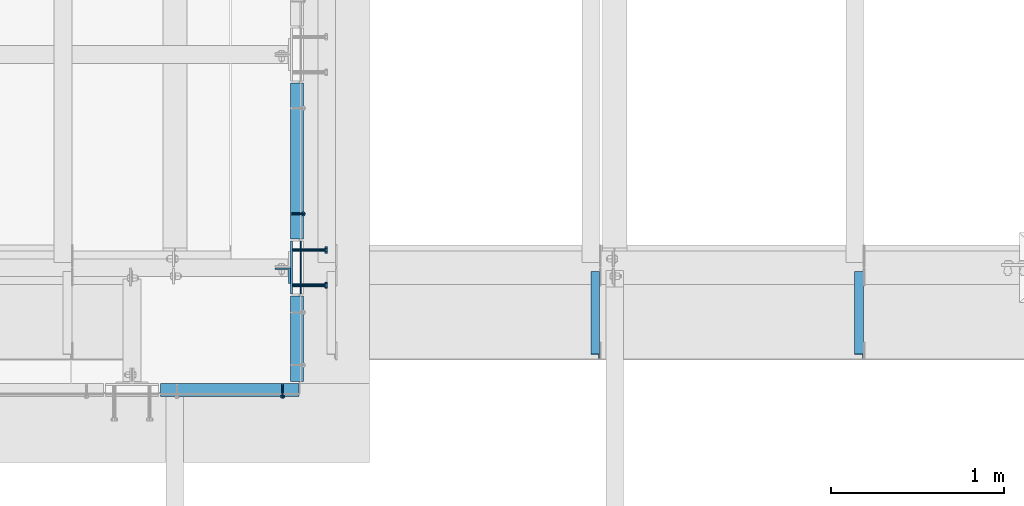
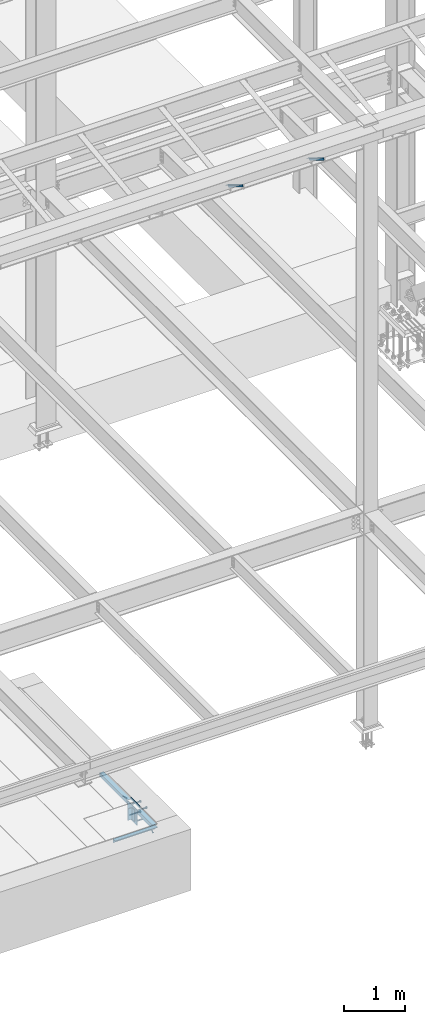
# One storey, part 2054 of 3843: 10 beams, 4 members, 7 elements without a shape of their own.
"""IFC2X3 building model written with IfcOpenShell, lengths in millimetres."""

from ifc_helpers import new_model, si_unit, frame, origin_with_axes, place, context, subcontext, project, spatial, faceted_brep, material, type_object, element, aggregate, save


model = new_model("IFC2X3")

# Units and contexts
model_context = context("Model", 3, precision=1e-05, world=origin_with_axes())
body_context = subcontext(model_context, "Body", "Model", "MODEL_VIEW")
ifc_project = project(units=[si_unit("LENGTHUNIT", "METRE", prefix="MILLI"), si_unit("AREAUNIT", "SQUARE_METRE"), si_unit("VOLUMEUNIT", "CUBIC_METRE"), si_unit("MASSUNIT", "GRAM", prefix="KILO"), si_unit("TIMEUNIT", "SECOND"), si_unit("PLANEANGLEUNIT", "RADIAN"), si_unit("SOLIDANGLEUNIT", "STERADIAN"), si_unit("THERMODYNAMICTEMPERATUREUNIT", "DEGREE_CELSIUS"), si_unit("LUMINOUSINTENSITYUNIT", "LUMEN")], contexts=[model_context])

# Site, building, storey
site_placement = place(None, origin_with_axes())
site = spatial("IfcSite", under=ifc_project, at=site_placement, CompositionType="ELEMENT")
building_placement = place(site_placement, origin_with_axes())
building = spatial("IfcBuilding", under=site, at=building_placement, Name="Undefined", CompositionType="ELEMENT")
storey_placement = place(building_placement, origin_with_axes())
storey = spatial("IfcBuildingStorey", under=building, at=storey_placement, Name="Undefined", CompositionType="ELEMENT", Elevation=0.0)

# Assembly, beam
assembly_1_placement = place(storey_placement, origin_with_axes())
assembly_1 = element("IfcElementAssembly", 1, at=assembly_1_placement, inside=storey, Name="EMBED PLATE", AssemblyPlace="NOTDEFINED", PredefinedType="RIGID_FRAME")
ifc_material_1 = material(Name="STEEL/A36")
beam_type_1 = type_object("IfcBeamType", PredefinedType="NOTDEFINED")
beam_1_placement = place(assembly_1_placement, frame((65903.475, 15151.1, 30454.6), z_axis=(0.0, 0.0, 1.0), x_axis=(0.0, -1.0, 0.0)))
beam_1 = element("IfcBeam", 2, at=beam_1_placement, type_object=beam_type_1, material=ifc_material_1, Name="PLATE", context=body_context, shape_type="Brep", body=[
    faceted_brep([(0.0, 3.17499999999927, -25.4000000000015), (0.0, 3.17499999999927, 25.4000000000015), (304.800000000003, 3.17500000000291, 25.4000000000015), (304.800000000003, 3.17500000000291, -25.4000000000015), (0.0, -3.17499999999927, 25.4000000000015), (304.800000000003, -3.17500000000291, 25.4000000000015), (0.0, -3.17499999999927, -25.4000000000015), (304.800000000003, -3.17500000000291, -25.4000000000015)], [[[0, 1, 2, 3]], [[1, 4, 5, 2]], [[4, 6, 7, 5]], [[6, 0, 3, 7]], [[5, 7, 3, 2]], [[6, 4, 1, 0]]]),
])

# Assembly, member
assembly_2_placement = place(storey_placement, origin_with_axes())
assembly_2 = element("IfcElementAssembly", 3, at=assembly_2_placement, inside=storey, Name="ANGLE", AssemblyPlace="NOTDEFINED", PredefinedType="RIGID_FRAME")
ifc_material_2 = material(Name="STEEL/A108")
member_type_1 = type_object("IfcMemberType", PredefinedType="NOTDEFINED")
member_1_placement = place(assembly_2_placement, frame((65849.5000002649, 15309.0561677558, 30422.8500045777), z_axis=(0.0, 1.0, 0.0), x_axis=(0.707106781186548, 0.0, -0.707106781186548)))
member_1 = element("IfcMember", 4, at=member_1_placement, type_object=member_type_1, material=ifc_material_2, Name="HEADED STUD ANCHOR", context=body_context, shape_type="Brep", body=[
    faceted_brep([(7.27595761418343e-12, -3.18000006675175, 5.5), (0.0, -5.49999999998363, 3.1800000667572), (94.4879985803855, -5.50000000011278, 3.1800000667572), (94.4879985803782, -3.18000006687362, 5.5), (0.0, -6.3499999046162, 0.0), (94.4879985803855, -6.34999990474535, 0.0), (0.0, -5.49999999998363, -3.1800000667572), (94.4879985803855, -5.50000000011278, -3.1800000667572), (7.27595761418343e-12, -3.18000006675175, -5.5), (94.4879985803782, -3.18000006687362, -5.5), (7.27595761418343e-12, -1.81898940354586e-12, -6.34999990463257), (94.4879985803782, -1.20053300634027e-10, -6.34999990463257), (0.0, 3.18000006675175, -5.5), (94.4879985803709, 3.18000006663351, -5.5), (7.27595761418343e-12, 5.49999999998363, -3.1800000667572), (94.4879985803709, 5.49999999987267, -3.1800000667572), (7.27595761418343e-12, 6.3499999046162, 0.0), (94.4879985803673, 6.34999990450706, 0.0), (7.27595761418343e-12, 5.49999999998363, 3.1800000667572), (94.4879985803709, 5.49999999987267, 3.1800000667572), (0.0, 3.18000006675175, 5.5), (94.4879985803709, 3.18000006663351, 5.5), (7.27595761418343e-12, -1.81898940354586e-12, 6.34999990463257), (94.4879985803782, -1.20053300634027e-10, 6.34999990463257), (96.5199985498621, -10.9899997712273, 6.34999990463257), (96.5199985498548, -6.34000015270249, 10.9899997711182), (96.5199985498621, -12.6999998093743, 0.0), (96.5199985498621, -10.9899997712273, -6.34999990463257), (96.5199985498548, -6.34000015270249, -10.9899997711182), (96.5199985498475, -1.21872290037572e-10, -12.6899995803833), (96.5199985498402, 6.34000015245874, -10.9899997711182), (96.519998549833, 10.9899997709817, -6.34999990463257), (96.519998549833, 12.6999998091305, 0.0), (96.519998549833, 10.9899997709817, 6.34999990463257), (96.5199985498402, 6.34000015245874, 10.9899997711182), (96.5199985498475, -1.21872290037572e-10, 12.6899995803833), (101.599998473539, -10.9899997712328, 6.34999990463257), (101.599998473532, -6.34000015270976, 10.9899997711182), (101.599998473539, -12.6999998093797, 0.0), (101.599998473539, -10.9899997712328, -6.34999990463257), (101.599998473532, -6.34000015270976, -10.9899997711182), (101.599998473524, -1.29148247651756e-10, -12.6899995803833), (101.599998473517, 6.34000015245329, -10.9899997711182), (101.59999847351, 10.9899997709763, -6.34999990463257), (101.599998473503, 12.6999998091196, 0.0), (101.59999847351, 10.9899997709763, 6.34999990463257), (101.599998473517, 6.34000015245329, 10.9899997711182), (101.599998473524, -1.29148247651756e-10, 12.6899995803833)], [[[0, 1, 2, 3]], [[1, 4, 5, 2]], [[4, 6, 7, 5]], [[6, 8, 9, 7]], [[8, 10, 11, 9]], [[10, 12, 13, 11]], [[12, 14, 15, 13]], [[14, 16, 17, 15]], [[16, 18, 19, 17]], [[18, 20, 21, 19]], [[20, 22, 23, 21]], [[22, 0, 3, 23]], [[22, 20, 18, 16, 14, 12, 10, 8, 6, 4, 1, 0]], [[3, 2, 24, 25]], [[2, 5, 26, 24]], [[5, 7, 27, 26]], [[7, 9, 28, 27]], [[9, 11, 29, 28]], [[11, 13, 30, 29]], [[13, 15, 31, 30]], [[15, 17, 32, 31]], [[17, 19, 33, 32]], [[19, 21, 34, 33]], [[21, 23, 35, 34]], [[23, 3, 25, 35]], [[25, 24, 36, 37]], [[24, 26, 38, 36]], [[26, 27, 39, 38]], [[27, 28, 40, 39]], [[28, 29, 41, 40]], [[29, 30, 42, 41]], [[30, 31, 43, 42]], [[31, 32, 44, 43]], [[32, 33, 45, 44]], [[33, 34, 46, 45]], [[34, 35, 47, 46]], [[35, 25, 37, 47]], [[38, 39, 40, 41, 42, 43, 44, 45, 46, 47, 37, 36]]]),
])

assembly_3_placement = place(storey_placement, origin_with_axes())
assembly_3 = element("IfcElementAssembly", 5, at=assembly_3_placement, inside=storey, Name="ANGLE", AssemblyPlace="NOTDEFINED", PredefinedType="RIGID_FRAME")
member_2_placement = place(assembly_3_placement, frame((65798.7000335676, 14322.4250721639, 30422.8500024177), z_axis=(1.0, 0.0, 0.0), x_axis=(0.0, -0.707106781186548, -0.707106781186548)))
member_2 = element("IfcMember", 6, at=member_2_placement, type_object=member_type_1, material=ifc_material_2, Name="HEADED STUD ANCHOR", context=body_context, shape_type="Brep", body=[
    faceted_brep([(7.27595761418343e-12, -3.18000006675175, 5.5), (0.0, -5.49999999998363, 3.1800000667572), (94.4879985803855, -5.50000000011278, 3.1800000667572), (94.4879985803782, -3.18000006687362, 5.5), (0.0, -6.3499999046162, 0.0), (94.4879985803855, -6.34999990474535, 0.0), (0.0, -5.49999999998363, -3.1800000667572), (94.4879985803855, -5.50000000011278, -3.1800000667572), (7.27595761418343e-12, -3.18000006675175, -5.5), (94.4879985803782, -3.18000006687362, -5.5), (7.27595761418343e-12, -1.81898940354586e-12, -6.34999990463257), (94.4879985803782, -1.20053300634027e-10, -6.34999990463257), (0.0, 3.18000006675175, -5.5), (94.4879985803709, 3.18000006663351, -5.5), (7.27595761418343e-12, 5.49999999998363, -3.1800000667572), (94.4879985803709, 5.49999999987267, -3.1800000667572), (7.27595761418343e-12, 6.3499999046162, 0.0), (94.4879985803673, 6.34999990450706, 0.0), (7.27595761418343e-12, 5.49999999998363, 3.1800000667572), (94.4879985803709, 5.49999999987267, 3.1800000667572), (0.0, 3.18000006675175, 5.5), (94.4879985803709, 3.18000006663351, 5.5), (7.27595761418343e-12, -1.81898940354586e-12, 6.34999990463257), (94.4879985803782, -1.20053300634027e-10, 6.34999990463257), (96.5199985498621, -10.9899997712273, 6.34999990463257), (96.5199985498548, -6.34000015270249, 10.9899997711182), (96.5199985498621, -12.6999998093743, 0.0), (96.5199985498621, -10.9899997712273, -6.34999990463257), (96.5199985498548, -6.34000015270249, -10.9899997711182), (96.5199985498475, -1.21872290037572e-10, -12.6899995803833), (96.5199985498402, 6.34000015245874, -10.9899997711182), (96.519998549833, 10.9899997709817, -6.34999990463257), (96.519998549833, 12.6999998091305, 0.0), (96.519998549833, 10.9899997709817, 6.34999990463257), (96.5199985498402, 6.34000015245874, 10.9899997711182), (96.5199985498475, -1.21872290037572e-10, 12.6899995803833), (101.599998473539, -10.9899997712328, 6.34999990463257), (101.599998473532, -6.34000015270976, 10.9899997711182), (101.599998473539, -12.6999998093797, 0.0), (101.599998473539, -10.9899997712328, -6.34999990463257), (101.599998473532, -6.34000015270976, -10.9899997711182), (101.599998473524, -1.29148247651756e-10, -12.6899995803833), (101.599998473517, 6.34000015245329, -10.9899997711182), (101.59999847351, 10.9899997709763, -6.34999990463257), (101.599998473503, 12.6999998091196, 0.0), (101.59999847351, 10.9899997709763, 6.34999990463257), (101.599998473517, 6.34000015245329, 10.9899997711182), (101.599998473524, -1.29148247651756e-10, 12.6899995803833)], [[[0, 1, 2, 3]], [[1, 4, 5, 2]], [[4, 6, 7, 5]], [[6, 8, 9, 7]], [[8, 10, 11, 9]], [[10, 12, 13, 11]], [[12, 14, 15, 13]], [[14, 16, 17, 15]], [[16, 18, 19, 17]], [[18, 20, 21, 19]], [[20, 22, 23, 21]], [[22, 0, 3, 23]], [[22, 20, 18, 16, 14, 12, 10, 8, 6, 4, 1, 0]], [[3, 2, 24, 25]], [[2, 5, 26, 24]], [[5, 7, 27, 26]], [[7, 9, 28, 27]], [[9, 11, 29, 28]], [[11, 13, 30, 29]], [[13, 15, 31, 30]], [[15, 17, 32, 31]], [[17, 19, 33, 32]], [[19, 21, 34, 33]], [[21, 23, 35, 34]], [[23, 3, 25, 35]], [[25, 24, 36, 37]], [[24, 26, 38, 36]], [[26, 27, 39, 38]], [[27, 28, 40, 39]], [[28, 29, 41, 40]], [[29, 30, 42, 41]], [[30, 31, 43, 42]], [[31, 32, 44, 43]], [[32, 33, 45, 44]], [[33, 34, 46, 45]], [[34, 35, 47, 46]], [[35, 25, 37, 47]], [[38, 39, 40, 41, 42, 43, 44, 45, 46, 47, 37, 36]]]),
])

# Beam
beam_type_2 = type_object("IfcBeamType", PredefinedType="NOTDEFINED")
beam_2_placement = place(assembly_1_placement, frame((65849.5, 14998.7, 30422.85), z_axis=(0.0, -1.0, 0.0), x_axis=(0.0, 0.0, -1.0)))
beam_2 = element("IfcBeam", 7, at=beam_2_placement, type_object=beam_type_2, material=ifc_material_1, Name="EMBED PLATE", context=body_context, shape_type="Brep", body=[
    faceted_brep([(-1.0550138540566e-10, 6.34999999999854, -152.400000000664), (1.0550138540566e-10, 6.34999999999854, 152.400000000656), (304.799999999999, 6.34999999999854, 152.400000000001), (304.799999999999, 6.34999999999854, -152.400000000001), (1.0550138540566e-10, -6.34999999999854, 152.400000000656), (304.799999999999, -6.34999999999854, 152.400000000001), (-1.0550138540566e-10, -6.34999999999854, -152.400000000664), (304.799999999999, -6.34999999999854, -152.400000000001)], [[[0, 1, 2, 3]], [[1, 4, 5, 2]], [[4, 6, 7, 5]], [[6, 0, 3, 7]], [[5, 7, 3, 2]], [[6, 4, 1, 0]]]),
])

# Assembly, member
assembly_4_placement = place(storey_placement, origin_with_axes())
assembly_4 = element("IfcElementAssembly", 8, at=assembly_4_placement, inside=storey, Name="ANGLE", AssemblyPlace="NOTDEFINED", PredefinedType="RIGID_FRAME")
ifc_material_3 = material(Name="STEEL/A572-50")
member_type_2 = type_object("IfcMemberType", Name="L2X2X1/4", PredefinedType="NOTDEFINED")
member_3_placement = place(assembly_4_placement, frame((69127.6875, 14962.4615149769, 42136.6100587905), z_axis=(-1.0, 0.0, 0.0), x_axis=(0.0, -0.851012521472712, 0.5251453972917)))
member_3 = element("IfcMember", 9, at=member_3_placement, type_object=member_type_2, material=ifc_material_3, Name="ANGLE", ObjectType="L2X2X1/4", context=body_context, shape_type="Brep", body=[
    faceted_brep([(0.0, 25.4000000000015, -25.4000000000015), (0.0, 25.4000000000015, 25.4000000000015), (558.799999999297, 25.3999999986918, 25.3999999999942), (558.799999999297, 25.3999999986918, -25.3999999999942), (0.0, 19.0500000000029, 25.4000000000015), (558.799999999297, 19.049999998686, 25.3999999999942), (0.0, 19.0500000000029, -19.0499999999993), (558.799999999297, 19.049999998686, -19.0500000000029), (0.0, -25.4000000000015, -19.0499999999993), (558.799999999281, -25.4000000013912, -19.0500000000029), (0.0, -25.4000000000015, -25.4000000000015), (558.799999999281, -25.4000000013912, -25.3999999999942)], [[[0, 1, 2, 3]], [[1, 4, 5, 2]], [[4, 6, 7, 5]], [[6, 8, 9, 7]], [[8, 10, 11, 9]], [[10, 0, 3, 11]], [[5, 7, 9, 11, 3, 2]], [[10, 8, 6, 4, 1, 0]]]),
])
aggregate(assembly_4, [member_3])

assembly_5_placement = place(storey_placement, origin_with_axes())
assembly_5 = element("IfcElementAssembly", 10, at=assembly_5_placement, inside=storey, Name="ANGLE", AssemblyPlace="NOTDEFINED", PredefinedType="RIGID_FRAME")
member_4_placement = place(assembly_5_placement, frame((67603.6875, 14962.4615149769, 42136.6100587905), z_axis=(-1.0, 0.0, 0.0), x_axis=(0.0, -0.851012521472712, 0.5251453972917)))
member_4 = element("IfcMember", 11, at=member_4_placement, type_object=member_type_2, material=ifc_material_3, Name="ANGLE", ObjectType="L2X2X1/4", context=body_context, shape_type="Brep", body=[
    faceted_brep([(0.0, 25.4000000000015, -25.4000000000015), (0.0, 25.4000000000015, 25.4000000000015), (558.799999999297, 25.3999999986918, 25.3999999999942), (558.799999999297, 25.3999999986918, -25.3999999999942), (0.0, 19.0500000000029, 25.4000000000015), (558.799999999297, 19.049999998686, 25.3999999999942), (0.0, 19.0500000000029, -19.0499999999993), (558.799999999297, 19.049999998686, -19.0500000000029), (0.0, -25.4000000000015, -19.0499999999993), (558.799999999281, -25.4000000013912, -19.0500000000029), (0.0, -25.4000000000015, -25.4000000000015), (558.799999999281, -25.4000000013912, -25.3999999999942)], [[[0, 1, 2, 3]], [[1, 4, 5, 2]], [[4, 6, 7, 5]], [[6, 8, 9, 7]], [[8, 10, 11, 9]], [[10, 0, 3, 11]], [[5, 7, 9, 11, 3, 2]], [[10, 8, 6, 4, 1, 0]]]),
])
aggregate(assembly_5, [member_4])

# Beam
beam_type_3 = type_object("IfcBeamType", Name="L3X3X1/4", PredefinedType="NOTDEFINED")
beam_3_placement = place(assembly_2_placement, frame((65881.2499980018, 16063.9121401411, 30391.1000045777), z_axis=(0.0, 0.0, -1.0), x_axis=(0.0, -1.0, 0.0)))
beam_3 = element("IfcBeam", 12, at=beam_3_placement, type_object=beam_type_3, material=ifc_material_1, Name="ANGLE", ObjectType="L3X3X1/4", context=body_context, shape_type="Brep", body=[
    faceted_brep([(0.0, 38.0999999999985, -38.0999999999985), (0.0, 38.0999999999985, 38.0999999999985), (900.112000000037, 38.1000000023996, 38.0999999999985), (900.112000000037, 38.1000000023996, -38.0999999999985), (0.0, 31.75, 38.0999999999985), (900.11200000003, 31.7500000023938, 38.0999999999985), (0.0, 31.75, -31.75), (900.11200000003, 31.7500000023938, -31.75), (0.0, -38.0999999999985, -31.75), (900.111999999965, -38.0999999976048, -31.75), (0.0, -38.0999999999985, -38.0999999999985), (900.111999999965, -38.0999999976048, -38.0999999999985)], [[[0, 1, 2, 3]], [[1, 4, 5, 2]], [[4, 6, 7, 5]], [[6, 8, 9, 7]], [[8, 10, 11, 9]], [[10, 0, 3, 11]], [[5, 7, 9, 11, 3, 2]], [[10, 8, 6, 4, 1, 0]]]),
])

aggregate(assembly_2, [member_1, beam_3])

# Assembly, beam
assembly_6_placement = place(storey_placement, origin_with_axes())
assembly_6 = element("IfcElementAssembly", 13, at=assembly_6_placement, inside=storey, Name="ANGLE", AssemblyPlace="NOTDEFINED", PredefinedType="RIGID_FRAME")
beam_4_placement = place(assembly_6_placement, frame((65881.2500246272, 14833.60037632, 30391.1000045777), z_axis=(0.0, 0.0, -1.0), x_axis=(0.0, -1.0, 0.0)))
beam_4 = element("IfcBeam", 14, at=beam_4_placement, type_object=beam_type_3, material=ifc_material_1, Name="ANGLE", ObjectType="L3X3X1/4", context=body_context, shape_type="Brep", body=[
    faceted_brep([(0.0, 38.0999999999985, -38.0999999999985), (0.0, 38.0999999999985, 38.0999999999985), (492.1249897337, 38.1000000025524, 38.0999999999985), (492.1249897337, 38.1000000025524, -38.0999999999985), (0.0, 31.75, 38.0999999999985), (492.124989733698, 31.7500000025466, 38.0999999999985), (0.0, 31.75, -31.75), (492.124989733698, 31.7500000025466, -31.75), (0.0, -38.0999999999985, -31.75), (492.124989733675, -38.0999999974447, -31.75), (0.0, -38.0999999999985, -38.0999999999985), (492.124989733675, -38.0999999974447, -38.0999999999985)], [[[0, 1, 2, 3]], [[1, 4, 5, 2]], [[4, 6, 7, 5]], [[6, 8, 9, 7]], [[8, 10, 11, 9]], [[10, 0, 3, 11]], [[5, 7, 9, 11, 3, 2]], [[10, 8, 6, 4, 1, 0]]]),
])
aggregate(assembly_6, [beam_4])

# Beam
beam_5_placement = place(assembly_3_placement, frame((65893.9500575394, 14290.6749906734, 30391.1000030518), z_axis=(0.0, 0.0, -1.0), x_axis=(-1.0, 0.0, 0.0)))
beam_5 = element("IfcBeam", 15, at=beam_5_placement, type_object=beam_type_3, material=ifc_material_1, Name="ANGLE", ObjectType="L3X3X1/4", context=body_context, shape_type="Brep", body=[
    faceted_brep([(0.0, 38.0999999999985, -38.0999999999985), (0.0, 38.0999999999985, 38.0999999999985), (800.10003051789, 38.0999999998003, 38.0999999999985), (800.10003051789, 38.0999999998003, -38.0999999999985), (0.0, 31.75, 38.0999999999985), (800.100030517875, 31.7499999997999, 38.0999999999985), (0.0, 31.75, -31.75), (800.100030517875, 31.7499999997999, -31.75), (0.0, -38.0999999999985, -31.75), (800.100030517729, -38.1000000002023, -31.75), (0.0, -38.0999999999985, -38.0999999999985), (800.100030517729, -38.1000000002023, -38.0999999999985)], [[[0, 1, 2, 3]], [[1, 4, 5, 2]], [[4, 6, 7, 5]], [[6, 8, 9, 7]], [[8, 10, 11, 9]], [[10, 0, 3, 11]], [[5, 7, 9, 11, 3, 2]], [[10, 8, 6, 4, 1, 0]]]),
])

aggregate(assembly_3, [member_2, beam_5])

# Assembly, beam
assembly_7_placement = place(storey_placement, origin_with_axes())
assembly_7 = element("IfcElementAssembly", 16, at=assembly_7_placement, inside=storey, Name="BEAM", AssemblyPlace="NOTDEFINED", PredefinedType="RIGID_FRAME")
beam_type_4 = type_object("IfcBeamType", Name="L3-1/2X3-1/2X3/8", PredefinedType="NOTDEFINED")
beam_6_placement = place(assembly_7_placement, frame((65798.7, 14951.075, 30391.1), z_axis=(0.0, -1.0, 0.0), x_axis=(0.0, 0.0, -1.0)))
beam_6 = element("IfcBeam", 17, at=beam_6_placement, type_object=beam_type_4, material=ifc_material_1, Name="ANGLE", ObjectType="L3-1/2X3-1/2X3/8", context=body_context, shape_type="Brep", body=[
    faceted_brep([(-3.63797880709171e-12, 44.4499999999971, -44.4500000000007), (-3.63797880709171e-12, 44.4499999999971, 44.4500000000007), (228.600000000006, 44.4499999999971, 44.4500000000007), (228.600000000006, 44.4499999999971, -44.4500000000007), (0.0, 34.9250000000029, 44.4500000000007), (228.600000000006, 34.9250000000029, 44.4500000000007), (0.0, 34.9250000000029, -34.9250000000029), (228.600000000006, 34.9250000000029, -34.9249999999993), (0.0, -44.4499999999971, -34.9249999999993), (228.600000000006, -44.4499999999971, -34.9249999999993), (3.63797880709171e-12, -44.4499999999971, -44.4500000000007), (228.600000000006, -44.4499999999971, -44.4500000000007)], [[[0, 1, 2, 3]], [[1, 4, 5, 2]], [[4, 6, 7, 5]], [[6, 8, 9, 7]], [[8, 10, 11, 9]], [[10, 0, 3, 11]], [[5, 7, 9, 11, 3, 2]], [[10, 8, 6, 4, 1, 0]]]),
])
aggregate(assembly_7, [beam_6])

# Beam
beam_type_5 = type_object("IfcBeamType", PredefinedType="NOTDEFINED")
beam_7_placement = place(assembly_1_placement, frame((65855.85, 15100.3, 30372.05), z_axis=(0.0, 1.0, 0.0), x_axis=(1.0, 0.0, 0.0)))
beam_7 = element("IfcBeam", 18, at=beam_7_placement, type_object=beam_type_5, material=ifc_material_2, Name="HEADED STUD ANCHOR", context=body_context, shape_type="Brep", body=[
    faceted_brep([(0.0, -9.52000045776367, 0.0), (0.0, -8.25, -4.76000022888184), (184.912000000004, -8.25, -4.76000022888184), (184.912000000004, -9.52000045776367, 0.0), (0.0, -4.76000022888184, -8.25), (184.912000000004, -4.76000022888184, -8.25), (0.0, 0.0, -9.52000045776367), (184.912000000004, 0.0, -9.52000045776367), (0.0, 4.76000022888184, -8.25), (184.912000000004, 4.76000022888184, -8.25), (0.0, 8.25, -4.76000022888184), (184.912000000004, 8.25, -4.76000022888184), (0.0, 9.52000045776367, 0.0), (184.912000000004, 9.52000045776367, 0.0), (0.0, 8.25, 4.76000022888184), (184.912000000004, 8.25, 4.76000022888184), (0.0, 4.76000022888184, 8.25), (184.912000000004, 4.76000022888184, 8.25), (0.0, 0.0, 9.52000045776367), (184.912000000004, 0.0, 9.52000045776367), (0.0, -4.76000022888184, 8.25), (184.912000000004, -4.76000022888184, 8.25), (0.0, -8.25, 4.76000022888184), (184.912000000004, -8.25, 4.76000022888184), (186.944000000003, -16.5, -9.52000045776367), (186.944000000003, -19.0499992370605, 0.0), (186.944000000003, -9.52000045776367, -16.5), (186.944000000003, 0.0, -19.0499992370605), (186.944000000003, 9.52000045776367, -16.5), (186.944000000003, 16.5, -9.52000045776367), (186.944000000003, 19.0499992370605, 0.0), (186.944000000003, 16.5, 9.52000045776367), (186.944000000003, 9.52000045776367, 16.5), (186.944000000003, 0.0, 19.0499992370605), (186.944000000003, -9.52000045776367, 16.5), (186.944000000003, -16.5, 9.52000045776367), (203.199999999997, -16.5, -9.52000045776367), (203.199999999997, -19.0499992370605, 0.0), (203.199999999997, -9.52000045776367, -16.5), (203.199999999997, 0.0, -19.0499992370605), (203.199999999997, 9.52000045776367, -16.5), (203.199999999997, 16.5, -9.52000045776367), (203.199999999997, 19.0499992370605, 0.0), (203.199999999997, 16.5, 9.52000045776367), (203.199999999997, 9.52000045776367, 16.5), (203.199999999997, 0.0, 19.0499992370605), (203.199999999997, -9.52000045776367, 16.5), (203.199999999997, -16.5, 9.52000045776367)], [[[0, 1, 2, 3]], [[1, 4, 5, 2]], [[4, 6, 7, 5]], [[6, 8, 9, 7]], [[8, 10, 11, 9]], [[10, 12, 13, 11]], [[12, 14, 15, 13]], [[14, 16, 17, 15]], [[16, 18, 19, 17]], [[18, 20, 21, 19]], [[20, 22, 23, 21]], [[22, 0, 3, 23]], [[22, 20, 18, 16, 14, 12, 10, 8, 6, 4, 1, 0]], [[3, 2, 24, 25]], [[2, 5, 26, 24]], [[5, 7, 27, 26]], [[7, 9, 28, 27]], [[9, 11, 29, 28]], [[11, 13, 30, 29]], [[13, 15, 31, 30]], [[15, 17, 32, 31]], [[17, 19, 33, 32]], [[19, 21, 34, 33]], [[21, 23, 35, 34]], [[23, 3, 25, 35]], [[25, 24, 36, 37]], [[24, 26, 38, 36]], [[26, 27, 39, 38]], [[27, 28, 40, 39]], [[28, 29, 41, 40]], [[29, 30, 42, 41]], [[30, 31, 43, 42]], [[31, 32, 44, 43]], [[32, 33, 45, 44]], [[33, 34, 46, 45]], [[34, 35, 47, 46]], [[35, 25, 37, 47]], [[38, 39, 40, 41, 42, 43, 44, 45, 46, 47, 37, 36]]]),
])

beam_8_placement = place(assembly_1_placement, frame((65855.85, 15100.3, 30168.85), z_axis=(0.0, 1.0, 0.0), x_axis=(1.0, 0.0, 0.0)))
beam_8 = element("IfcBeam", 19, at=beam_8_placement, type_object=beam_type_5, material=ifc_material_2, Name="HEADED STUD ANCHOR", context=body_context, shape_type="Brep", body=[
    faceted_brep([(0.0, -9.52000045776367, 0.0), (0.0, -8.25, -4.76000022888184), (184.912000000004, -8.25, -4.76000022888184), (184.912000000004, -9.52000045776367, 0.0), (0.0, -4.76000022888184, -8.25), (184.912000000004, -4.76000022888184, -8.25), (0.0, 0.0, -9.52000045776367), (184.912000000004, 0.0, -9.52000045776367), (0.0, 4.76000022888184, -8.25), (184.912000000004, 4.76000022888184, -8.25), (0.0, 8.25, -4.76000022888184), (184.912000000004, 8.25, -4.76000022888184), (0.0, 9.52000045776367, 0.0), (184.912000000004, 9.52000045776367, 0.0), (0.0, 8.25, 4.76000022888184), (184.912000000004, 8.25, 4.76000022888184), (0.0, 4.76000022888184, 8.25), (184.912000000004, 4.76000022888184, 8.25), (0.0, 0.0, 9.52000045776367), (184.912000000004, 0.0, 9.52000045776367), (0.0, -4.76000022888184, 8.25), (184.912000000004, -4.76000022888184, 8.25), (0.0, -8.25, 4.76000022888184), (184.912000000004, -8.25, 4.76000022888184), (186.944000000003, -16.5, -9.52000045776367), (186.944000000003, -19.0499992370605, 0.0), (186.944000000003, -9.52000045776367, -16.5), (186.944000000003, 0.0, -19.0499992370605), (186.944000000003, 9.52000045776367, -16.5), (186.944000000003, 16.5, -9.52000045776367), (186.944000000003, 19.0499992370605, 0.0), (186.944000000003, 16.5, 9.52000045776367), (186.944000000003, 9.52000045776367, 16.5), (186.944000000003, 0.0, 19.0499992370605), (186.944000000003, -9.52000045776367, 16.5), (186.944000000003, -16.5, 9.52000045776367), (203.199999999997, -16.5, -9.52000045776367), (203.199999999997, -19.0499992370605, 0.0), (203.199999999997, -9.52000045776367, -16.5), (203.199999999997, 0.0, -19.0499992370605), (203.199999999997, 9.52000045776367, -16.5), (203.199999999997, 16.5, -9.52000045776367), (203.199999999997, 19.0499992370605, 0.0), (203.199999999997, 16.5, 9.52000045776367), (203.199999999997, 9.52000045776367, 16.5), (203.199999999997, 0.0, 19.0499992370605), (203.199999999997, -9.52000045776367, 16.5), (203.199999999997, -16.5, 9.52000045776367)], [[[0, 1, 2, 3]], [[1, 4, 5, 2]], [[4, 6, 7, 5]], [[6, 8, 9, 7]], [[8, 10, 11, 9]], [[10, 12, 13, 11]], [[12, 14, 15, 13]], [[14, 16, 17, 15]], [[16, 18, 19, 17]], [[18, 20, 21, 19]], [[20, 22, 23, 21]], [[22, 0, 3, 23]], [[22, 20, 18, 16, 14, 12, 10, 8, 6, 4, 1, 0]], [[3, 2, 24, 25]], [[2, 5, 26, 24]], [[5, 7, 27, 26]], [[7, 9, 28, 27]], [[9, 11, 29, 28]], [[11, 13, 30, 29]], [[13, 15, 31, 30]], [[15, 17, 32, 31]], [[17, 19, 33, 32]], [[19, 21, 34, 33]], [[21, 23, 35, 34]], [[23, 3, 25, 35]], [[25, 24, 36, 37]], [[24, 26, 38, 36]], [[26, 27, 39, 38]], [[27, 28, 40, 39]], [[28, 29, 41, 40]], [[29, 30, 42, 41]], [[30, 31, 43, 42]], [[31, 32, 44, 43]], [[32, 33, 45, 44]], [[33, 34, 46, 45]], [[34, 35, 47, 46]], [[35, 25, 37, 47]], [[38, 39, 40, 41, 42, 43, 44, 45, 46, 47, 37, 36]]]),
])

beam_9_placement = place(assembly_1_placement, frame((65855.85, 14897.1, 30372.05), z_axis=(0.0, 1.0, 0.0), x_axis=(1.0, 0.0, 0.0)))
beam_9 = element("IfcBeam", 20, at=beam_9_placement, type_object=beam_type_5, material=ifc_material_1, Name="PLATE", context=body_context, shape_type="Brep", body=[
    faceted_brep([(0.0, -9.52000045776367, 0.0), (0.0, -8.25, -4.76000022888184), (184.912000000004, -8.25, -4.76000022888184), (184.912000000004, -9.52000045776367, 0.0), (0.0, -4.76000022888184, -8.25), (184.912000000004, -4.76000022888184, -8.25), (0.0, 0.0, -9.52000045776367), (184.912000000004, 0.0, -9.52000045776367), (0.0, 4.76000022888184, -8.25), (184.912000000004, 4.76000022888184, -8.25), (0.0, 8.25, -4.76000022888184), (184.912000000004, 8.25, -4.76000022888184), (0.0, 9.52000045776367, 0.0), (184.912000000004, 9.52000045776367, 0.0), (0.0, 8.25, 4.76000022888184), (184.912000000004, 8.25, 4.76000022888184), (0.0, 4.76000022888184, 8.25), (184.912000000004, 4.76000022888184, 8.25), (0.0, 0.0, 9.52000045776367), (184.912000000004, 0.0, 9.52000045776367), (0.0, -4.76000022888184, 8.25), (184.912000000004, -4.76000022888184, 8.25), (0.0, -8.25, 4.76000022888184), (184.912000000004, -8.25, 4.76000022888184), (186.944000000003, -16.5, -9.52000045776367), (186.944000000003, -19.0499992370605, 0.0), (186.944000000003, -9.52000045776367, -16.5), (186.944000000003, 0.0, -19.0499992370605), (186.944000000003, 9.52000045776367, -16.5), (186.944000000003, 16.5, -9.52000045776367), (186.944000000003, 19.0499992370605, 0.0), (186.944000000003, 16.5, 9.52000045776367), (186.944000000003, 9.52000045776367, 16.5), (186.944000000003, 0.0, 19.0499992370605), (186.944000000003, -9.52000045776367, 16.5), (186.944000000003, -16.5, 9.52000045776367), (203.199999999997, -16.5, -9.52000045776367), (203.199999999997, -19.0499992370605, 0.0), (203.199999999997, -9.52000045776367, -16.5), (203.199999999997, 0.0, -19.0499992370605), (203.199999999997, 9.52000045776367, -16.5), (203.199999999997, 16.5, -9.52000045776367), (203.199999999997, 19.0499992370605, 0.0), (203.199999999997, 16.5, 9.52000045776367), (203.199999999997, 9.52000045776367, 16.5), (203.199999999997, 0.0, 19.0499992370605), (203.199999999997, -9.52000045776367, 16.5), (203.199999999997, -16.5, 9.52000045776367)], [[[0, 1, 2, 3]], [[1, 4, 5, 2]], [[4, 6, 7, 5]], [[6, 8, 9, 7]], [[8, 10, 11, 9]], [[10, 12, 13, 11]], [[12, 14, 15, 13]], [[14, 16, 17, 15]], [[16, 18, 19, 17]], [[18, 20, 21, 19]], [[20, 22, 23, 21]], [[22, 0, 3, 23]], [[22, 20, 18, 16, 14, 12, 10, 8, 6, 4, 1, 0]], [[3, 2, 24, 25]], [[2, 5, 26, 24]], [[5, 7, 27, 26]], [[7, 9, 28, 27]], [[9, 11, 29, 28]], [[11, 13, 30, 29]], [[13, 15, 31, 30]], [[15, 17, 32, 31]], [[17, 19, 33, 32]], [[19, 21, 34, 33]], [[21, 23, 35, 34]], [[23, 3, 25, 35]], [[25, 24, 36, 37]], [[24, 26, 38, 36]], [[26, 27, 39, 38]], [[27, 28, 40, 39]], [[28, 29, 41, 40]], [[29, 30, 42, 41]], [[30, 31, 43, 42]], [[31, 32, 44, 43]], [[32, 33, 45, 44]], [[33, 34, 46, 45]], [[34, 35, 47, 46]], [[35, 25, 37, 47]], [[38, 39, 40, 41, 42, 43, 44, 45, 46, 47, 37, 36]]]),
])

beam_10_placement = place(assembly_1_placement, frame((65855.85, 14897.1, 30168.85), z_axis=(0.0, 1.0, 0.0), x_axis=(1.0, 0.0, 0.0)))
beam_10 = element("IfcBeam", 21, at=beam_10_placement, type_object=beam_type_5, material=ifc_material_2, Name="HEADED STUD ANCHOR", context=body_context, shape_type="Brep", body=[
    faceted_brep([(0.0, -9.52000045776367, 0.0), (0.0, -8.25, -4.76000022888184), (184.912000000004, -8.25, -4.76000022888184), (184.912000000004, -9.52000045776367, 0.0), (0.0, -4.76000022888184, -8.25), (184.912000000004, -4.76000022888184, -8.25), (0.0, 0.0, -9.52000045776367), (184.912000000004, 0.0, -9.52000045776367), (0.0, 4.76000022888184, -8.25), (184.912000000004, 4.76000022888184, -8.25), (0.0, 8.25, -4.76000022888184), (184.912000000004, 8.25, -4.76000022888184), (0.0, 9.52000045776367, 0.0), (184.912000000004, 9.52000045776367, 0.0), (0.0, 8.25, 4.76000022888184), (184.912000000004, 8.25, 4.76000022888184), (0.0, 4.76000022888184, 8.25), (184.912000000004, 4.76000022888184, 8.25), (0.0, 0.0, 9.52000045776367), (184.912000000004, 0.0, 9.52000045776367), (0.0, -4.76000022888184, 8.25), (184.912000000004, -4.76000022888184, 8.25), (0.0, -8.25, 4.76000022888184), (184.912000000004, -8.25, 4.76000022888184), (186.944000000003, -16.5, -9.52000045776367), (186.944000000003, -19.0499992370605, 0.0), (186.944000000003, -9.52000045776367, -16.5), (186.944000000003, 0.0, -19.0499992370605), (186.944000000003, 9.52000045776367, -16.5), (186.944000000003, 16.5, -9.52000045776367), (186.944000000003, 19.0499992370605, 0.0), (186.944000000003, 16.5, 9.52000045776367), (186.944000000003, 9.52000045776367, 16.5), (186.944000000003, 0.0, 19.0499992370605), (186.944000000003, -9.52000045776367, 16.5), (186.944000000003, -16.5, 9.52000045776367), (203.199999999997, -16.5, -9.52000045776367), (203.199999999997, -19.0499992370605, 0.0), (203.199999999997, -9.52000045776367, -16.5), (203.199999999997, 0.0, -19.0499992370605), (203.199999999997, 9.52000045776367, -16.5), (203.199999999997, 16.5, -9.52000045776367), (203.199999999997, 19.0499992370605, 0.0), (203.199999999997, 16.5, 9.52000045776367), (203.199999999997, 9.52000045776367, 16.5), (203.199999999997, 0.0, 19.0499992370605), (203.199999999997, -9.52000045776367, 16.5), (203.199999999997, -16.5, 9.52000045776367)], [[[0, 1, 2, 3]], [[1, 4, 5, 2]], [[4, 6, 7, 5]], [[6, 8, 9, 7]], [[8, 10, 11, 9]], [[10, 12, 13, 11]], [[12, 14, 15, 13]], [[14, 16, 17, 15]], [[16, 18, 19, 17]], [[18, 20, 21, 19]], [[20, 22, 23, 21]], [[22, 0, 3, 23]], [[22, 20, 18, 16, 14, 12, 10, 8, 6, 4, 1, 0]], [[3, 2, 24, 25]], [[2, 5, 26, 24]], [[5, 7, 27, 26]], [[7, 9, 28, 27]], [[9, 11, 29, 28]], [[11, 13, 30, 29]], [[13, 15, 31, 30]], [[15, 17, 32, 31]], [[17, 19, 33, 32]], [[19, 21, 34, 33]], [[21, 23, 35, 34]], [[23, 3, 25, 35]], [[25, 24, 36, 37]], [[24, 26, 38, 36]], [[26, 27, 39, 38]], [[27, 28, 40, 39]], [[28, 29, 41, 40]], [[29, 30, 42, 41]], [[30, 31, 43, 42]], [[31, 32, 44, 43]], [[32, 33, 45, 44]], [[33, 34, 46, 45]], [[34, 35, 47, 46]], [[35, 25, 37, 47]], [[38, 39, 40, 41, 42, 43, 44, 45, 46, 47, 37, 36]]]),
])

aggregate(assembly_1, [beam_1, beam_7, beam_8, beam_9, beam_10, beam_2])

save(model, "model.ifc")
